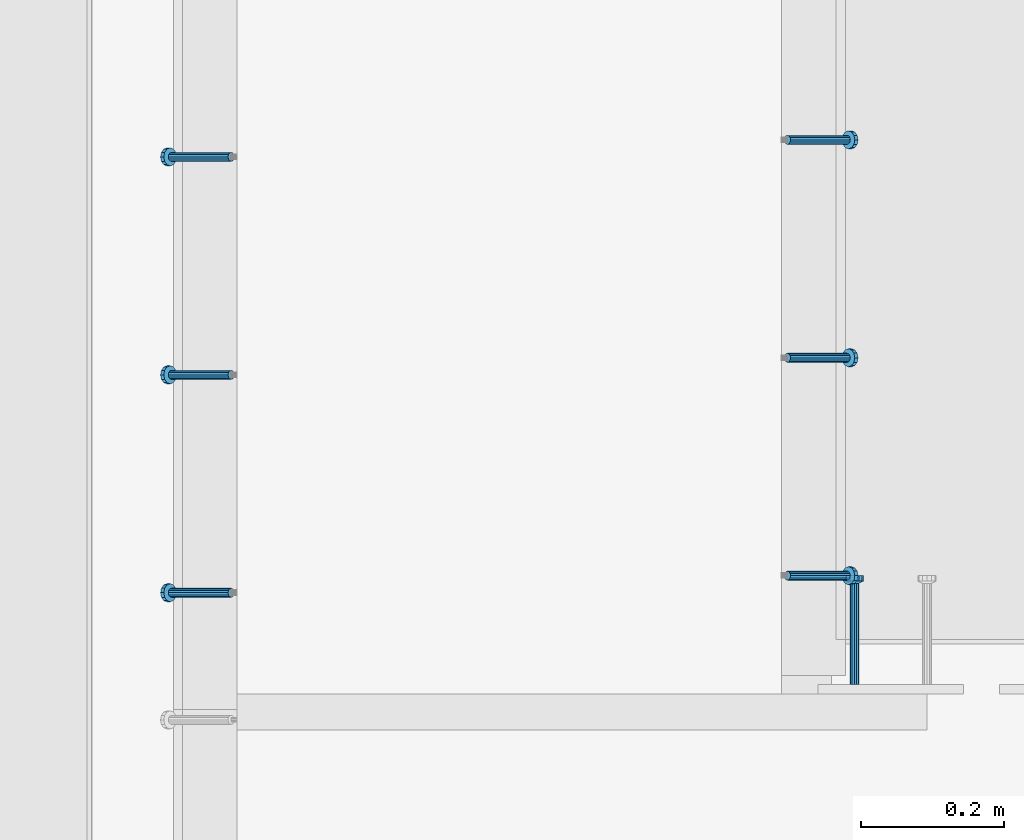
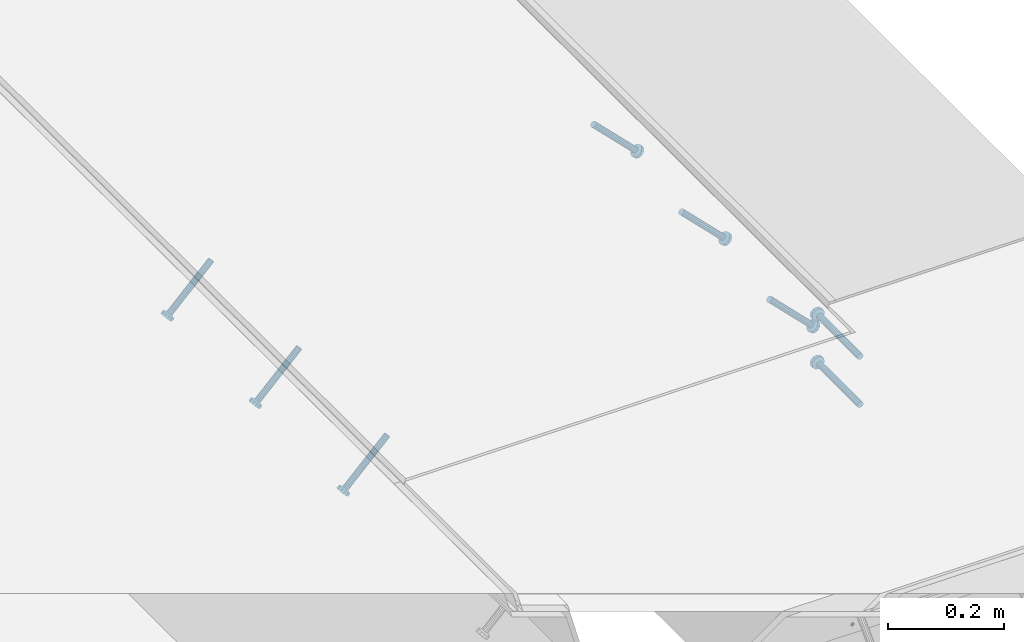
# One storey, part 2030 of 3843: 6 members, 2 beams, 3 elements without a shape of their own.
"""IFC2X3 building model written with IfcOpenShell, lengths in millimetres."""

from ifc_helpers import new_model, si_unit, frame, origin_with_axes, place, context, subcontext, project, spatial, faceted_brep, material, type_object, element, aggregate, save


model = new_model("IFC2X3")

# Units and contexts
model_context = context("Model", 3, precision=1e-05, world=origin_with_axes())
body_context = subcontext(model_context, "Body", "Model", "MODEL_VIEW")
ifc_project = project(units=[si_unit("LENGTHUNIT", "METRE", prefix="MILLI"), si_unit("AREAUNIT", "SQUARE_METRE"), si_unit("VOLUMEUNIT", "CUBIC_METRE"), si_unit("MASSUNIT", "GRAM", prefix="KILO"), si_unit("TIMEUNIT", "SECOND"), si_unit("PLANEANGLEUNIT", "RADIAN"), si_unit("SOLIDANGLEUNIT", "STERADIAN"), si_unit("THERMODYNAMICTEMPERATUREUNIT", "DEGREE_CELSIUS"), si_unit("LUMINOUSINTENSITYUNIT", "LUMEN")], contexts=[model_context])

# Site, building, storey
site_placement = place(None, origin_with_axes())
site = spatial("IfcSite", under=ifc_project, at=site_placement, CompositionType="ELEMENT")
building_placement = place(site_placement, origin_with_axes())
building = spatial("IfcBuilding", under=site, at=building_placement, Name="Undefined", CompositionType="ELEMENT")
storey_placement = place(building_placement, origin_with_axes())
storey = spatial("IfcBuildingStorey", under=building, at=storey_placement, Name="Undefined", CompositionType="ELEMENT", Elevation=0.0)

# Assembly, members
assembly_1_placement = place(storey_placement, origin_with_axes())
assembly_1 = element("IfcElementAssembly", 1, at=assembly_1_placement, inside=storey, Name="EMBED_ANGLE", AssemblyPlace="NOTDEFINED", PredefinedType="RIGID_FRAME")
ifc_material = material(Name="STEEL/A108")
member_type = type_object("IfcMemberType", PredefinedType="NOTDEFINED")
member_1_placement = place(assembly_1_placement, frame((44851.3835, 26990.674, 30456.1875), z_axis=(0.0, 1.0, 0.0), x_axis=(0.707106781186548, 0.0, -0.707106781186548)))
member_1 = element("IfcMember", 2, at=member_1_placement, type_object=member_type, material=ifc_material, Name="HEADED STUD ANCHOR", context=body_context, shape_type="Brep", body=[
    faceted_brep([(7.27595761418343e-12, -3.18000006675175, 5.5), (0.0, -5.49999999998363, 3.1800000667572), (118.110000000976, -5.49999999999091, 3.1800000667572), (118.110000000983, -3.18000006675175, 5.5), (0.0, -6.3499999046162, 0.0), (118.110000000968, -6.34999990461256, 0.0), (0.0, -5.49999999998363, -3.1800000667572), (118.110000000976, -5.49999999999091, -3.1800000667572), (7.27595761418343e-12, -3.18000006675175, -5.5), (118.110000000983, -3.18000006675175, -5.5), (7.27595761418343e-12, -1.81898940354586e-12, -6.34999990463257), (118.110000000968, -1.81898940354586e-12, -6.34999990463257), (0.0, 3.18000006675175, -5.5), (118.110000000968, 3.18000006674811, -5.5), (7.27595761418343e-12, 5.49999999998363, -3.1800000667572), (118.110000000983, 5.49999999998363, -3.1800000667572), (7.27595761418343e-12, 6.3499999046162, 0.0), (118.110000000976, 6.34999990461256, 0.0), (7.27595761418343e-12, 5.49999999998363, 3.1800000667572), (118.110000000983, 5.49999999998363, 3.1800000667572), (0.0, 3.18000006675175, 5.5), (118.110000000968, 3.18000006674811, 5.5), (7.27595761418343e-12, -1.81898940354586e-12, 6.34999990463257), (118.110000000968, -1.81898940354586e-12, 6.34999990463257), (120.650000000991, -10.9899997710909, 6.34999990463257), (120.650000000998, -6.34000015257152, 10.9899997711182), (120.650000000991, -12.6999998092379, 0.0), (120.650000000991, -10.9899997710909, -6.34999990463257), (120.650000000998, -6.34000015257152, -10.9899997711182), (120.650000000991, -1.81898940354586e-12, -12.6899995803833), (120.650000000991, 6.34000015257152, -10.9899997711182), (120.650000000998, 10.9899997710909, -6.34999990463257), (120.650000000991, 12.6999998092342, 0.0), (120.650000000998, 10.9899997710909, 6.34999990463257), (120.650000000991, 6.34000015257152, 10.9899997711182), (120.650000000991, -1.81898940354586e-12, 12.6899995803833), (127.000000001048, -10.9899997710945, 6.34999990463257), (127.000000001048, -6.34000015257152, 10.9899997711182), (127.000000001048, -12.6999998092342, 0.0), (127.000000001048, -10.9899997710945, -6.34999990463257), (127.000000001048, -6.34000015257152, -10.9899997711182), (127.000000001048, 1.81898940354586e-12, -12.6899995803833), (127.000000001048, 6.34000015256788, -10.9899997711182), (127.000000001048, 10.9899997710909, -6.34999990463257), (127.000000001048, 12.6999998092379, 0.0), (127.000000001048, 10.9899997710909, 6.34999990463257), (127.000000001048, 6.34000015256788, 10.9899997711182), (127.000000001048, 1.81898940354586e-12, 12.6899995803833)], [[[0, 1, 2, 3]], [[1, 4, 5, 2]], [[4, 6, 7, 5]], [[6, 8, 9, 7]], [[8, 10, 11, 9]], [[10, 12, 13, 11]], [[12, 14, 15, 13]], [[14, 16, 17, 15]], [[16, 18, 19, 17]], [[18, 20, 21, 19]], [[20, 22, 23, 21]], [[22, 0, 3, 23]], [[22, 20, 18, 16, 14, 12, 10, 8, 6, 4, 1, 0]], [[3, 2, 24, 25]], [[2, 5, 26, 24]], [[5, 7, 27, 26]], [[7, 9, 28, 27]], [[9, 11, 29, 28]], [[11, 13, 30, 29]], [[13, 15, 31, 30]], [[15, 17, 32, 31]], [[17, 19, 33, 32]], [[19, 21, 34, 33]], [[21, 23, 35, 34]], [[23, 3, 25, 35]], [[25, 24, 36, 37]], [[24, 26, 38, 36]], [[26, 27, 39, 38]], [[27, 28, 40, 39]], [[28, 29, 41, 40]], [[29, 30, 42, 41]], [[30, 31, 43, 42]], [[31, 32, 44, 43]], [[32, 33, 45, 44]], [[33, 34, 46, 45]], [[34, 35, 47, 46]], [[35, 25, 37, 47]], [[38, 39, 40, 41, 42, 43, 44, 45, 46, 47, 37, 36]]]),
])
member_2_placement = place(assembly_1_placement, frame((44851.3835, 27295.474, 30456.1875), z_axis=(0.0, 1.0, 0.0), x_axis=(0.707106781186548, 0.0, -0.707106781186548)))
member_2 = element("IfcMember", 3, at=member_2_placement, type_object=member_type, material=ifc_material, Name="HEADED STUD ANCHOR", context=body_context, shape_type="Brep", body=[
    faceted_brep([(7.27595761418343e-12, -3.18000006675175, 5.5), (0.0, -5.49999999998363, 3.1800000667572), (118.110000000976, -5.49999999999091, 3.1800000667572), (118.110000000983, -3.18000006675175, 5.5), (0.0, -6.3499999046162, 0.0), (118.110000000968, -6.34999990461256, 0.0), (0.0, -5.49999999998363, -3.1800000667572), (118.110000000976, -5.49999999999091, -3.1800000667572), (7.27595761418343e-12, -3.18000006675175, -5.5), (118.110000000983, -3.18000006675175, -5.5), (7.27595761418343e-12, -1.81898940354586e-12, -6.34999990463257), (118.110000000968, -1.81898940354586e-12, -6.34999990463257), (0.0, 3.18000006675175, -5.5), (118.110000000968, 3.18000006674811, -5.5), (7.27595761418343e-12, 5.49999999998363, -3.1800000667572), (118.110000000983, 5.49999999998363, -3.1800000667572), (7.27595761418343e-12, 6.3499999046162, 0.0), (118.110000000976, 6.34999990461256, 0.0), (7.27595761418343e-12, 5.49999999998363, 3.1800000667572), (118.110000000983, 5.49999999998363, 3.1800000667572), (0.0, 3.18000006675175, 5.5), (118.110000000968, 3.18000006674811, 5.5), (7.27595761418343e-12, -1.81898940354586e-12, 6.34999990463257), (118.110000000968, -1.81898940354586e-12, 6.34999990463257), (120.650000000991, -10.9899997710909, 6.34999990463257), (120.650000000998, -6.34000015257152, 10.9899997711182), (120.650000000991, -12.6999998092379, 0.0), (120.650000000991, -10.9899997710909, -6.34999990463257), (120.650000000998, -6.34000015257152, -10.9899997711182), (120.650000000991, -1.81898940354586e-12, -12.6899995803833), (120.650000000991, 6.34000015257152, -10.9899997711182), (120.650000000998, 10.9899997710909, -6.34999990463257), (120.650000000991, 12.6999998092342, 0.0), (120.650000000998, 10.9899997710909, 6.34999990463257), (120.650000000991, 6.34000015257152, 10.9899997711182), (120.650000000991, -1.81898940354586e-12, 12.6899995803833), (127.000000001048, -10.9899997710945, 6.34999990463257), (127.000000001048, -6.34000015257152, 10.9899997711182), (127.000000001048, -12.6999998092342, 0.0), (127.000000001048, -10.9899997710945, -6.34999990463257), (127.000000001048, -6.34000015257152, -10.9899997711182), (127.000000001048, 1.81898940354586e-12, -12.6899995803833), (127.000000001048, 6.34000015256788, -10.9899997711182), (127.000000001048, 10.9899997710909, -6.34999990463257), (127.000000001048, 12.6999998092379, 0.0), (127.000000001048, 10.9899997710909, 6.34999990463257), (127.000000001048, 6.34000015256788, 10.9899997711182), (127.000000001048, 1.81898940354586e-12, 12.6899995803833)], [[[0, 1, 2, 3]], [[1, 4, 5, 2]], [[4, 6, 7, 5]], [[6, 8, 9, 7]], [[8, 10, 11, 9]], [[10, 12, 13, 11]], [[12, 14, 15, 13]], [[14, 16, 17, 15]], [[16, 18, 19, 17]], [[18, 20, 21, 19]], [[20, 22, 23, 21]], [[22, 0, 3, 23]], [[22, 20, 18, 16, 14, 12, 10, 8, 6, 4, 1, 0]], [[3, 2, 24, 25]], [[2, 5, 26, 24]], [[5, 7, 27, 26]], [[7, 9, 28, 27]], [[9, 11, 29, 28]], [[11, 13, 30, 29]], [[13, 15, 31, 30]], [[15, 17, 32, 31]], [[17, 19, 33, 32]], [[19, 21, 34, 33]], [[21, 23, 35, 34]], [[23, 3, 25, 35]], [[25, 24, 36, 37]], [[24, 26, 38, 36]], [[26, 27, 39, 38]], [[27, 28, 40, 39]], [[28, 29, 41, 40]], [[29, 30, 42, 41]], [[30, 31, 43, 42]], [[31, 32, 44, 43]], [[32, 33, 45, 44]], [[33, 34, 46, 45]], [[34, 35, 47, 46]], [[35, 25, 37, 47]], [[38, 39, 40, 41, 42, 43, 44, 45, 46, 47, 37, 36]]]),
])
member_3_placement = place(assembly_1_placement, frame((44851.3835, 27600.274, 30456.1875), z_axis=(0.0, 1.0, 0.0), x_axis=(0.707106781186548, 0.0, -0.707106781186548)))
member_3 = element("IfcMember", 4, at=member_3_placement, type_object=member_type, material=ifc_material, Name="HEADED STUD ANCHOR", context=body_context, shape_type="Brep", body=[
    faceted_brep([(7.27595761418343e-12, -3.18000006675175, 5.5), (0.0, -5.49999999998363, 3.1800000667572), (118.110000000976, -5.49999999999091, 3.1800000667572), (118.110000000983, -3.18000006675175, 5.5), (0.0, -6.3499999046162, 0.0), (118.110000000968, -6.34999990461256, 0.0), (0.0, -5.49999999998363, -3.1800000667572), (118.110000000976, -5.49999999999091, -3.1800000667572), (7.27595761418343e-12, -3.18000006675175, -5.5), (118.110000000983, -3.18000006675175, -5.5), (7.27595761418343e-12, -1.81898940354586e-12, -6.34999990463257), (118.110000000968, -1.81898940354586e-12, -6.34999990463257), (0.0, 3.18000006675175, -5.5), (118.110000000968, 3.18000006674811, -5.5), (7.27595761418343e-12, 5.49999999998363, -3.1800000667572), (118.110000000983, 5.49999999998363, -3.1800000667572), (7.27595761418343e-12, 6.3499999046162, 0.0), (118.110000000976, 6.34999990461256, 0.0), (7.27595761418343e-12, 5.49999999998363, 3.1800000667572), (118.110000000983, 5.49999999998363, 3.1800000667572), (0.0, 3.18000006675175, 5.5), (118.110000000968, 3.18000006674811, 5.5), (7.27595761418343e-12, -1.81898940354586e-12, 6.34999990463257), (118.110000000968, -1.81898940354586e-12, 6.34999990463257), (120.650000000991, -10.9899997710909, 6.34999990463257), (120.650000000998, -6.34000015257152, 10.9899997711182), (120.650000000991, -12.6999998092379, 0.0), (120.650000000991, -10.9899997710909, -6.34999990463257), (120.650000000998, -6.34000015257152, -10.9899997711182), (120.650000000991, -1.81898940354586e-12, -12.6899995803833), (120.650000000991, 6.34000015257152, -10.9899997711182), (120.650000000998, 10.9899997710909, -6.34999990463257), (120.650000000991, 12.6999998092342, 0.0), (120.650000000998, 10.9899997710909, 6.34999990463257), (120.650000000991, 6.34000015257152, 10.9899997711182), (120.650000000991, -1.81898940354586e-12, 12.6899995803833), (127.000000001048, -10.9899997710945, 6.34999990463257), (127.000000001048, -6.34000015257152, 10.9899997711182), (127.000000001048, -12.6999998092342, 0.0), (127.000000001048, -10.9899997710945, -6.34999990463257), (127.000000001048, -6.34000015257152, -10.9899997711182), (127.000000001048, 1.81898940354586e-12, -12.6899995803833), (127.000000001048, 6.34000015256788, -10.9899997711182), (127.000000001048, 10.9899997710909, -6.34999990463257), (127.000000001048, 12.6999998092379, 0.0), (127.000000001048, 10.9899997710909, 6.34999990463257), (127.000000001048, 6.34000015256788, 10.9899997711182), (127.000000001048, 1.81898940354586e-12, 12.6899995803833)], [[[0, 1, 2, 3]], [[1, 4, 5, 2]], [[4, 6, 7, 5]], [[6, 8, 9, 7]], [[8, 10, 11, 9]], [[10, 12, 13, 11]], [[12, 14, 15, 13]], [[14, 16, 17, 15]], [[16, 18, 19, 17]], [[18, 20, 21, 19]], [[20, 22, 23, 21]], [[22, 0, 3, 23]], [[22, 20, 18, 16, 14, 12, 10, 8, 6, 4, 1, 0]], [[3, 2, 24, 25]], [[2, 5, 26, 24]], [[5, 7, 27, 26]], [[7, 9, 28, 27]], [[9, 11, 29, 28]], [[11, 13, 30, 29]], [[13, 15, 31, 30]], [[15, 17, 32, 31]], [[17, 19, 33, 32]], [[19, 21, 34, 33]], [[21, 23, 35, 34]], [[23, 3, 25, 35]], [[25, 24, 36, 37]], [[24, 26, 38, 36]], [[26, 27, 39, 38]], [[27, 28, 40, 39]], [[28, 29, 41, 40]], [[29, 30, 42, 41]], [[30, 31, 43, 42]], [[31, 32, 44, 43]], [[32, 33, 45, 44]], [[33, 34, 46, 45]], [[34, 35, 47, 46]], [[35, 25, 37, 47]], [[38, 39, 40, 41, 42, 43, 44, 45, 46, 47, 37, 36]]]),
])
aggregate(assembly_1, [member_1, member_2, member_3])

assembly_2_placement = place(storey_placement, origin_with_axes())
assembly_2 = element("IfcElementAssembly", 5, at=assembly_2_placement, inside=storey, Name="EMBED_ANGLE", AssemblyPlace="NOTDEFINED", PredefinedType="RIGID_FRAME")
member_4_placement = place(assembly_2_placement, frame((44073.5085109405, 26966.8627577615, 30456.1874999998), z_axis=(0.0, -1.0, 0.0), x_axis=(-0.707106781186548, 0.0, -0.707106781186548)))
member_4 = element("IfcMember", 6, at=member_4_placement, type_object=member_type, material=ifc_material, Name="HEADED STUD ANCHOR", context=body_context, shape_type="Brep", body=[
    faceted_brep([(7.27595761418343e-12, -3.18000006675175, 5.5), (0.0, -5.49999999998363, 3.1800000667572), (118.110000000976, -5.49999999999091, 3.1800000667572), (118.110000000983, -3.18000006675175, 5.5), (0.0, -6.3499999046162, 0.0), (118.110000000968, -6.34999990461256, 0.0), (0.0, -5.49999999998363, -3.1800000667572), (118.110000000976, -5.49999999999091, -3.1800000667572), (7.27595761418343e-12, -3.18000006675175, -5.5), (118.110000000983, -3.18000006675175, -5.5), (7.27595761418343e-12, -1.81898940354586e-12, -6.34999990463257), (118.110000000968, -1.81898940354586e-12, -6.34999990463257), (0.0, 3.18000006675175, -5.5), (118.110000000968, 3.18000006674811, -5.5), (7.27595761418343e-12, 5.49999999998363, -3.1800000667572), (118.110000000983, 5.49999999998363, -3.1800000667572), (7.27595761418343e-12, 6.3499999046162, 0.0), (118.110000000976, 6.34999990461256, 0.0), (7.27595761418343e-12, 5.49999999998363, 3.1800000667572), (118.110000000983, 5.49999999998363, 3.1800000667572), (0.0, 3.18000006675175, 5.5), (118.110000000968, 3.18000006674811, 5.5), (7.27595761418343e-12, -1.81898940354586e-12, 6.34999990463257), (118.110000000968, -1.81898940354586e-12, 6.34999990463257), (120.650000000991, -10.9899997710909, 6.34999990463257), (120.650000000998, -6.34000015257152, 10.9899997711182), (120.650000000991, -12.6999998092379, 0.0), (120.650000000991, -10.9899997710909, -6.34999990463257), (120.650000000998, -6.34000015257152, -10.9899997711182), (120.650000000991, -1.81898940354586e-12, -12.6899995803833), (120.650000000991, 6.34000015257152, -10.9899997711182), (120.650000000998, 10.9899997710909, -6.34999990463257), (120.650000000991, 12.6999998092342, 0.0), (120.650000000998, 10.9899997710909, 6.34999990463257), (120.650000000991, 6.34000015257152, 10.9899997711182), (120.650000000991, -1.81898940354586e-12, 12.6899995803833), (127.000000001048, -10.9899997710945, 6.34999990463257), (127.000000001048, -6.34000015257152, 10.9899997711182), (127.000000001048, -12.6999998092342, 0.0), (127.000000001048, -10.9899997710945, -6.34999990463257), (127.000000001048, -6.34000015257152, -10.9899997711182), (127.000000001048, 1.81898940354586e-12, -12.6899995803833), (127.000000001048, 6.34000015256788, -10.9899997711182), (127.000000001048, 10.9899997710909, -6.34999990463257), (127.000000001048, 12.6999998092379, 0.0), (127.000000001048, 10.9899997710909, 6.34999990463257), (127.000000001048, 6.34000015256788, 10.9899997711182), (127.000000001048, 1.81898940354586e-12, 12.6899995803833)], [[[0, 1, 2, 3]], [[1, 4, 5, 2]], [[4, 6, 7, 5]], [[6, 8, 9, 7]], [[8, 10, 11, 9]], [[10, 12, 13, 11]], [[12, 14, 15, 13]], [[14, 16, 17, 15]], [[16, 18, 19, 17]], [[18, 20, 21, 19]], [[20, 22, 23, 21]], [[22, 0, 3, 23]], [[22, 20, 18, 16, 14, 12, 10, 8, 6, 4, 1, 0]], [[3, 2, 24, 25]], [[2, 5, 26, 24]], [[5, 7, 27, 26]], [[7, 9, 28, 27]], [[9, 11, 29, 28]], [[11, 13, 30, 29]], [[13, 15, 31, 30]], [[15, 17, 32, 31]], [[17, 19, 33, 32]], [[19, 21, 34, 33]], [[21, 23, 35, 34]], [[23, 3, 25, 35]], [[25, 24, 36, 37]], [[24, 26, 38, 36]], [[26, 27, 39, 38]], [[27, 28, 40, 39]], [[28, 29, 41, 40]], [[29, 30, 42, 41]], [[30, 31, 43, 42]], [[31, 32, 44, 43]], [[32, 33, 45, 44]], [[33, 34, 46, 45]], [[34, 35, 47, 46]], [[35, 25, 37, 47]], [[38, 39, 40, 41, 42, 43, 44, 45, 46, 47, 37, 36]]]),
])
member_5_placement = place(assembly_2_placement, frame((44073.5085109404, 27271.6627455545, 30456.1874999998), z_axis=(0.0, -1.0, 0.0), x_axis=(-0.707106781186548, 0.0, -0.707106781186548)))
member_5 = element("IfcMember", 7, at=member_5_placement, type_object=member_type, material=ifc_material, Name="HEADED STUD ANCHOR", context=body_context, shape_type="Brep", body=[
    faceted_brep([(7.27595761418343e-12, -3.18000006675175, 5.5), (0.0, -5.49999999998363, 3.1800000667572), (118.110000000976, -5.49999999999091, 3.1800000667572), (118.110000000983, -3.18000006675175, 5.5), (0.0, -6.3499999046162, 0.0), (118.110000000968, -6.34999990461256, 0.0), (0.0, -5.49999999998363, -3.1800000667572), (118.110000000976, -5.49999999999091, -3.1800000667572), (7.27595761418343e-12, -3.18000006675175, -5.5), (118.110000000983, -3.18000006675175, -5.5), (7.27595761418343e-12, -1.81898940354586e-12, -6.34999990463257), (118.110000000968, -1.81898940354586e-12, -6.34999990463257), (0.0, 3.18000006675175, -5.5), (118.110000000968, 3.18000006674811, -5.5), (7.27595761418343e-12, 5.49999999998363, -3.1800000667572), (118.110000000983, 5.49999999998363, -3.1800000667572), (7.27595761418343e-12, 6.3499999046162, 0.0), (118.110000000976, 6.34999990461256, 0.0), (7.27595761418343e-12, 5.49999999998363, 3.1800000667572), (118.110000000983, 5.49999999998363, 3.1800000667572), (0.0, 3.18000006675175, 5.5), (118.110000000968, 3.18000006674811, 5.5), (7.27595761418343e-12, -1.81898940354586e-12, 6.34999990463257), (118.110000000968, -1.81898940354586e-12, 6.34999990463257), (120.650000000991, -10.9899997710909, 6.34999990463257), (120.650000000998, -6.34000015257152, 10.9899997711182), (120.650000000991, -12.6999998092379, 0.0), (120.650000000991, -10.9899997710909, -6.34999990463257), (120.650000000998, -6.34000015257152, -10.9899997711182), (120.650000000991, -1.81898940354586e-12, -12.6899995803833), (120.650000000991, 6.34000015257152, -10.9899997711182), (120.650000000998, 10.9899997710909, -6.34999990463257), (120.650000000991, 12.6999998092342, 0.0), (120.650000000998, 10.9899997710909, 6.34999990463257), (120.650000000991, 6.34000015257152, 10.9899997711182), (120.650000000991, -1.81898940354586e-12, 12.6899995803833), (127.000000001048, -10.9899997710945, 6.34999990463257), (127.000000001048, -6.34000015257152, 10.9899997711182), (127.000000001048, -12.6999998092342, 0.0), (127.000000001048, -10.9899997710945, -6.34999990463257), (127.000000001048, -6.34000015257152, -10.9899997711182), (127.000000001048, 1.81898940354586e-12, -12.6899995803833), (127.000000001048, 6.34000015256788, -10.9899997711182), (127.000000001048, 10.9899997710909, -6.34999990463257), (127.000000001048, 12.6999998092379, 0.0), (127.000000001048, 10.9899997710909, 6.34999990463257), (127.000000001048, 6.34000015256788, 10.9899997711182), (127.000000001048, 1.81898940354586e-12, 12.6899995803833)], [[[0, 1, 2, 3]], [[1, 4, 5, 2]], [[4, 6, 7, 5]], [[6, 8, 9, 7]], [[8, 10, 11, 9]], [[10, 12, 13, 11]], [[12, 14, 15, 13]], [[14, 16, 17, 15]], [[16, 18, 19, 17]], [[18, 20, 21, 19]], [[20, 22, 23, 21]], [[22, 0, 3, 23]], [[22, 20, 18, 16, 14, 12, 10, 8, 6, 4, 1, 0]], [[3, 2, 24, 25]], [[2, 5, 26, 24]], [[5, 7, 27, 26]], [[7, 9, 28, 27]], [[9, 11, 29, 28]], [[11, 13, 30, 29]], [[13, 15, 31, 30]], [[15, 17, 32, 31]], [[17, 19, 33, 32]], [[19, 21, 34, 33]], [[21, 23, 35, 34]], [[23, 3, 25, 35]], [[25, 24, 36, 37]], [[24, 26, 38, 36]], [[26, 27, 39, 38]], [[27, 28, 40, 39]], [[28, 29, 41, 40]], [[29, 30, 42, 41]], [[30, 31, 43, 42]], [[31, 32, 44, 43]], [[32, 33, 45, 44]], [[33, 34, 46, 45]], [[34, 35, 47, 46]], [[35, 25, 37, 47]], [[38, 39, 40, 41, 42, 43, 44, 45, 46, 47, 37, 36]]]),
])
member_6_placement = place(assembly_2_placement, frame((44073.5085109405, 27576.462763865, 30456.1874999998), z_axis=(0.0, -1.0, 0.0), x_axis=(-0.707106781186548, 0.0, -0.707106781186548)))
member_6 = element("IfcMember", 8, at=member_6_placement, type_object=member_type, material=ifc_material, Name="HEADED STUD ANCHOR", context=body_context, shape_type="Brep", body=[
    faceted_brep([(7.27595761418343e-12, -3.18000006675175, 5.5), (0.0, -5.49999999998363, 3.1800000667572), (118.110000000976, -5.49999999999091, 3.1800000667572), (118.110000000983, -3.18000006675175, 5.5), (0.0, -6.3499999046162, 0.0), (118.110000000968, -6.34999990461256, 0.0), (0.0, -5.49999999998363, -3.1800000667572), (118.110000000976, -5.49999999999091, -3.1800000667572), (7.27595761418343e-12, -3.18000006675175, -5.5), (118.110000000983, -3.18000006675175, -5.5), (7.27595761418343e-12, -1.81898940354586e-12, -6.34999990463257), (118.110000000968, -1.81898940354586e-12, -6.34999990463257), (0.0, 3.18000006675175, -5.5), (118.110000000968, 3.18000006674811, -5.5), (7.27595761418343e-12, 5.49999999998363, -3.1800000667572), (118.110000000983, 5.49999999998363, -3.1800000667572), (7.27595761418343e-12, 6.3499999046162, 0.0), (118.110000000976, 6.34999990461256, 0.0), (7.27595761418343e-12, 5.49999999998363, 3.1800000667572), (118.110000000983, 5.49999999998363, 3.1800000667572), (0.0, 3.18000006675175, 5.5), (118.110000000968, 3.18000006674811, 5.5), (7.27595761418343e-12, -1.81898940354586e-12, 6.34999990463257), (118.110000000968, -1.81898940354586e-12, 6.34999990463257), (120.650000000991, -10.9899997710909, 6.34999990463257), (120.650000000998, -6.34000015257152, 10.9899997711182), (120.650000000991, -12.6999998092379, 0.0), (120.650000000991, -10.9899997710909, -6.34999990463257), (120.650000000998, -6.34000015257152, -10.9899997711182), (120.650000000991, -1.81898940354586e-12, -12.6899995803833), (120.650000000991, 6.34000015257152, -10.9899997711182), (120.650000000998, 10.9899997710909, -6.34999990463257), (120.650000000991, 12.6999998092342, 0.0), (120.650000000998, 10.9899997710909, 6.34999990463257), (120.650000000991, 6.34000015257152, 10.9899997711182), (120.650000000991, -1.81898940354586e-12, 12.6899995803833), (127.000000001048, -10.9899997710945, 6.34999990463257), (127.000000001048, -6.34000015257152, 10.9899997711182), (127.000000001048, -12.6999998092342, 0.0), (127.000000001048, -10.9899997710945, -6.34999990463257), (127.000000001048, -6.34000015257152, -10.9899997711182), (127.000000001048, 1.81898940354586e-12, -12.6899995803833), (127.000000001048, 6.34000015256788, -10.9899997711182), (127.000000001048, 10.9899997710909, -6.34999990463257), (127.000000001048, 12.6999998092379, 0.0), (127.000000001048, 10.9899997710909, 6.34999990463257), (127.000000001048, 6.34000015256788, 10.9899997711182), (127.000000001048, 1.81898940354586e-12, 12.6899995803833)], [[[0, 1, 2, 3]], [[1, 4, 5, 2]], [[4, 6, 7, 5]], [[6, 8, 9, 7]], [[8, 10, 11, 9]], [[10, 12, 13, 11]], [[12, 14, 15, 13]], [[14, 16, 17, 15]], [[16, 18, 19, 17]], [[18, 20, 21, 19]], [[20, 22, 23, 21]], [[22, 0, 3, 23]], [[22, 20, 18, 16, 14, 12, 10, 8, 6, 4, 1, 0]], [[3, 2, 24, 25]], [[2, 5, 26, 24]], [[5, 7, 27, 26]], [[7, 9, 28, 27]], [[9, 11, 29, 28]], [[11, 13, 30, 29]], [[13, 15, 31, 30]], [[15, 17, 32, 31]], [[17, 19, 33, 32]], [[19, 21, 34, 33]], [[21, 23, 35, 34]], [[23, 3, 25, 35]], [[25, 24, 36, 37]], [[24, 26, 38, 36]], [[26, 27, 39, 38]], [[27, 28, 40, 39]], [[28, 29, 41, 40]], [[29, 30, 42, 41]], [[30, 31, 43, 42]], [[31, 32, 44, 43]], [[32, 33, 45, 44]], [[33, 34, 46, 45]], [[34, 35, 47, 46]], [[35, 25, 37, 47]], [[38, 39, 40, 41, 42, 43, 44, 45, 46, 47, 37, 36]]]),
])
aggregate(assembly_2, [member_4, member_5, member_6])

# Assembly, beams
assembly_3_placement = place(storey_placement, origin_with_axes())
assembly_3 = element("IfcElementAssembly", 9, at=assembly_3_placement, inside=storey, Name="EMBED PLATE", AssemblyPlace="NOTDEFINED", PredefinedType="RIGID_FRAME")
beam_type = type_object("IfcBeamType", PredefinedType="NOTDEFINED")
beam_1_placement = place(assembly_3_placement, frame((44945.0459999909, 26838.2734618944, 30394.275), z_axis=(-1.0, 0.0, 0.0), x_axis=(0.0, 1.0, 0.0)))
beam_1 = element("IfcBeam", 10, at=beam_1_placement, type_object=beam_type, material=ifc_material, Name="HEADED STUD ANCHOR", context=body_context, shape_type="Brep", body=[
    faceted_brep([(7.27595761418343e-12, -3.18000006675175, 5.5), (0.0, -5.49999999998363, 3.1800000667572), (141.731999999989, -5.5, 3.1800000667572), (141.731999999989, -3.1800000667572, 5.5), (0.0, -6.3499999046162, 0.0), (141.731999999989, -6.34999990463257, 0.0), (0.0, -5.49999999998363, -3.1800000667572), (141.731999999989, -5.5, -3.1800000667572), (7.27595761418343e-12, -3.18000006675175, -5.5), (141.731999999989, -3.1800000667572, -5.5), (7.27595761418343e-12, -1.81898940354586e-12, -6.34999990463257), (141.731999999989, 0.0, -6.34999990463257), (0.0, 3.18000006675175, -5.5), (141.731999999989, 3.1800000667572, -5.5), (7.27595761418343e-12, 5.49999999998363, -3.1800000667572), (141.731999999989, 5.5, -3.1800000667572), (7.27595761418343e-12, 6.3499999046162, 0.0), (141.731999999989, 6.34999990463257, 0.0), (7.27595761418343e-12, 5.49999999998363, 3.1800000667572), (141.731999999989, 5.5, 3.1800000667572), (0.0, 3.18000006675175, 5.5), (141.731999999989, 3.1800000667572, 5.5), (7.27595761418343e-12, -1.81898940354586e-12, 6.34999990463257), (141.731999999989, 0.0, 6.34999990463257), (144.779999999999, -10.9899997711182, 6.34999990463257), (144.779999999999, -6.34000015258789, 10.9899997711182), (144.779999999999, -12.6999998092651, 0.0), (144.779999999999, -10.9899997711182, -6.34999990463257), (144.779999999999, -6.34000015258789, -10.9899997711182), (144.779999999999, 0.0, -12.6899995803833), (144.779999999999, 6.34000015258789, -10.9899997711182), (144.779999999999, 10.9899997711182, -6.34999990463257), (144.779999999999, 12.6999998092651, 0.0), (144.779999999999, 10.9899997711182, 6.34999990463257), (144.779999999999, 6.34000015258789, 10.9899997711182), (144.779999999999, 0.0, 12.6899995803833), (152.399999999994, -10.9899997711182, 6.34999990463257), (152.399999999994, -6.34000015258789, 10.9899997711182), (152.399999999994, -12.6999998092651, 0.0), (152.399999999994, -10.9899997711182, -6.34999990463257), (152.399999999994, -6.34000015258789, -10.9899997711182), (152.399999999994, 0.0, -12.6899995803833), (152.399999999994, 6.34000015258789, -10.9899997711182), (152.399999999994, 10.9899997711182, -6.34999990463257), (152.399999999994, 12.6999998092651, 0.0), (152.399999999994, 10.9899997711182, 6.34999990463257), (152.399999999994, 6.34000015258789, 10.9899997711182), (152.399999999994, 0.0, 12.6899995803833)], [[[0, 1, 2, 3]], [[1, 4, 5, 2]], [[4, 6, 7, 5]], [[6, 8, 9, 7]], [[8, 10, 11, 9]], [[10, 12, 13, 11]], [[12, 14, 15, 13]], [[14, 16, 17, 15]], [[16, 18, 19, 17]], [[18, 20, 21, 19]], [[20, 22, 23, 21]], [[22, 0, 3, 23]], [[22, 20, 18, 16, 14, 12, 10, 8, 6, 4, 1, 0]], [[3, 2, 24, 25]], [[2, 5, 26, 24]], [[5, 7, 27, 26]], [[7, 9, 28, 27]], [[9, 11, 29, 28]], [[11, 13, 30, 29]], [[13, 15, 31, 30]], [[15, 17, 32, 31]], [[17, 19, 33, 32]], [[19, 21, 34, 33]], [[21, 23, 35, 34]], [[23, 3, 25, 35]], [[25, 24, 36, 37]], [[24, 26, 38, 36]], [[26, 27, 39, 38]], [[27, 28, 40, 39]], [[28, 29, 41, 40]], [[29, 30, 42, 41]], [[30, 31, 43, 42]], [[31, 32, 44, 43]], [[32, 33, 45, 44]], [[33, 34, 46, 45]], [[34, 35, 47, 46]], [[35, 25, 37, 47]], [[38, 39, 40, 41, 42, 43, 44, 45, 46, 47, 37, 36]]]),
])
beam_2_placement = place(assembly_3_placement, frame((44945.0459999909, 26838.2734618944, 30292.675), z_axis=(-1.0, 0.0, 0.0), x_axis=(0.0, 1.0, 0.0)))
beam_2 = element("IfcBeam", 11, at=beam_2_placement, type_object=beam_type, material=ifc_material, Name="HEADED STUD ANCHOR", context=body_context, shape_type="Brep", body=[
    faceted_brep([(7.27595761418343e-12, -3.18000006675175, 5.5), (0.0, -5.49999999998363, 3.1800000667572), (141.731999999989, -5.5, 3.1800000667572), (141.731999999989, -3.1800000667572, 5.5), (0.0, -6.3499999046162, 0.0), (141.731999999989, -6.34999990463257, 0.0), (0.0, -5.49999999998363, -3.1800000667572), (141.731999999989, -5.5, -3.1800000667572), (7.27595761418343e-12, -3.18000006675175, -5.5), (141.731999999989, -3.1800000667572, -5.5), (7.27595761418343e-12, -1.81898940354586e-12, -6.34999990463257), (141.731999999989, 0.0, -6.34999990463257), (0.0, 3.18000006675175, -5.5), (141.731999999989, 3.1800000667572, -5.5), (7.27595761418343e-12, 5.49999999998363, -3.1800000667572), (141.731999999989, 5.5, -3.1800000667572), (7.27595761418343e-12, 6.3499999046162, 0.0), (141.731999999989, 6.34999990463257, 0.0), (7.27595761418343e-12, 5.49999999998363, 3.1800000667572), (141.731999999989, 5.5, 3.1800000667572), (0.0, 3.18000006675175, 5.5), (141.731999999989, 3.1800000667572, 5.5), (7.27595761418343e-12, -1.81898940354586e-12, 6.34999990463257), (141.731999999989, 0.0, 6.34999990463257), (144.779999999999, -10.9899997711182, 6.34999990463257), (144.779999999999, -6.34000015258789, 10.9899997711182), (144.779999999999, -12.6999998092651, 0.0), (144.779999999999, -10.9899997711182, -6.34999990463257), (144.779999999999, -6.34000015258789, -10.9899997711182), (144.779999999999, 0.0, -12.6899995803833), (144.779999999999, 6.34000015258789, -10.9899997711182), (144.779999999999, 10.9899997711182, -6.34999990463257), (144.779999999999, 12.6999998092651, 0.0), (144.779999999999, 10.9899997711182, 6.34999990463257), (144.779999999999, 6.34000015258789, 10.9899997711182), (144.779999999999, 0.0, 12.6899995803833), (152.399999999994, -10.9899997711182, 6.34999990463257), (152.399999999994, -6.34000015258789, 10.9899997711182), (152.399999999994, -12.6999998092651, 0.0), (152.399999999994, -10.9899997711182, -6.34999990463257), (152.399999999994, -6.34000015258789, -10.9899997711182), (152.399999999994, 0.0, -12.6899995803833), (152.399999999994, 6.34000015258789, -10.9899997711182), (152.399999999994, 10.9899997711182, -6.34999990463257), (152.399999999994, 12.6999998092651, 0.0), (152.399999999994, 10.9899997711182, 6.34999990463257), (152.399999999994, 6.34000015258789, 10.9899997711182), (152.399999999994, 0.0, 12.6899995803833)], [[[0, 1, 2, 3]], [[1, 4, 5, 2]], [[4, 6, 7, 5]], [[6, 8, 9, 7]], [[8, 10, 11, 9]], [[10, 12, 13, 11]], [[12, 14, 15, 13]], [[14, 16, 17, 15]], [[16, 18, 19, 17]], [[18, 20, 21, 19]], [[20, 22, 23, 21]], [[22, 0, 3, 23]], [[22, 20, 18, 16, 14, 12, 10, 8, 6, 4, 1, 0]], [[3, 2, 24, 25]], [[2, 5, 26, 24]], [[5, 7, 27, 26]], [[7, 9, 28, 27]], [[9, 11, 29, 28]], [[11, 13, 30, 29]], [[13, 15, 31, 30]], [[15, 17, 32, 31]], [[17, 19, 33, 32]], [[19, 21, 34, 33]], [[21, 23, 35, 34]], [[23, 3, 25, 35]], [[25, 24, 36, 37]], [[24, 26, 38, 36]], [[26, 27, 39, 38]], [[27, 28, 40, 39]], [[28, 29, 41, 40]], [[29, 30, 42, 41]], [[30, 31, 43, 42]], [[31, 32, 44, 43]], [[32, 33, 45, 44]], [[33, 34, 46, 45]], [[34, 35, 47, 46]], [[35, 25, 37, 47]], [[38, 39, 40, 41, 42, 43, 44, 45, 46, 47, 37, 36]]]),
])
aggregate(assembly_3, [beam_1, beam_2])

save(model, "model.ifc")
